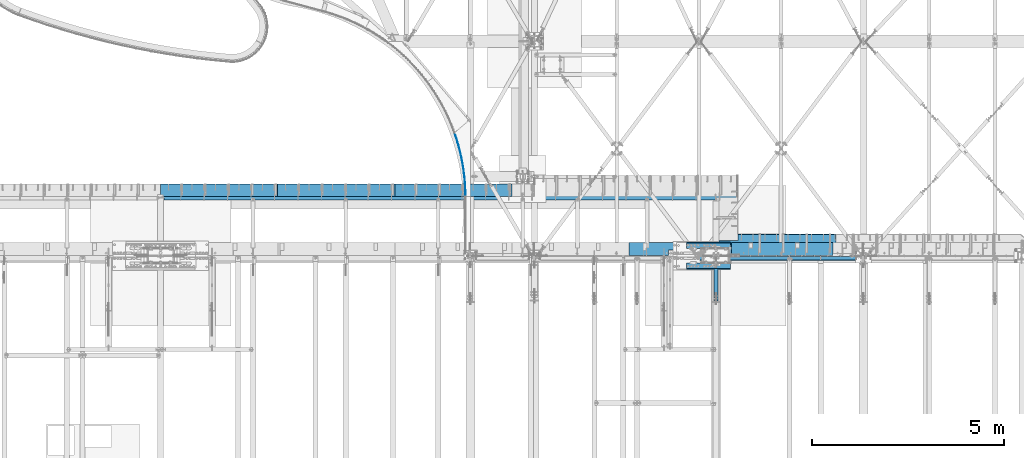
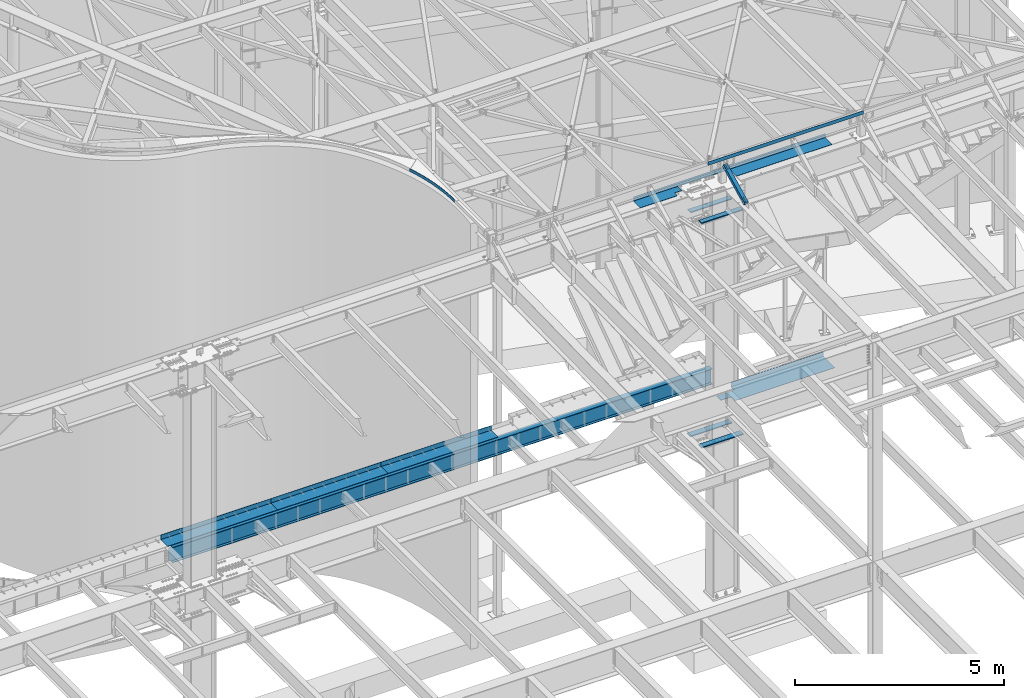
# One storey, part 1146 of 1763: 13 beams, 1 member, 8 elements without a shape of their own.
"""IFC2X3 building model written with IfcOpenShell, lengths in millimetres."""

from ifc_helpers import new_model, si_unit, frame, origin_with_axes, place, context, subcontext, project, spatial, faceted_brep, material, type_object, element, aggregate, save


model = new_model("IFC2X3")

# Units and contexts
model_context = context("Model", 3, precision=1e-05, world=origin_with_axes())
body_context = subcontext(model_context, "Body", "Model", "MODEL_VIEW")
ifc_project = project(units=[si_unit("LENGTHUNIT", "METRE", prefix="MILLI"), si_unit("AREAUNIT", "SQUARE_METRE"), si_unit("VOLUMEUNIT", "CUBIC_METRE"), si_unit("MASSUNIT", "GRAM", prefix="KILO"), si_unit("TIMEUNIT", "SECOND"), si_unit("PLANEANGLEUNIT", "RADIAN"), si_unit("SOLIDANGLEUNIT", "STERADIAN"), si_unit("THERMODYNAMICTEMPERATUREUNIT", "DEGREE_CELSIUS"), si_unit("LUMINOUSINTENSITYUNIT", "LUMEN")], contexts=[model_context])

# Site, building, storey
site_placement = place(None, origin_with_axes())
site = spatial("IfcSite", under=ifc_project, at=site_placement, CompositionType="ELEMENT")
building_placement = place(site_placement, origin_with_axes())
building = spatial("IfcBuilding", under=site, at=building_placement, Name="Undefined", CompositionType="ELEMENT")
storey_placement = place(building_placement, origin_with_axes())
storey = spatial("IfcBuildingStorey", under=building, at=storey_placement, Name="Undefined", CompositionType="ELEMENT", Elevation=0.0)

# Assembly, beam
assembly_1_placement = place(storey_placement, origin_with_axes())
assembly_1 = element("IfcElementAssembly", 1, at=assembly_1_placement, inside=storey, Name="BEAM", AssemblyPlace="NOTDEFINED", PredefinedType="RIGID_FRAME")
ifc_material_1 = material(Name="STEEL/A36")
beam_type_1 = type_object("IfcBeamType", Name="L4X4X1/4", PredefinedType="NOTDEFINED")
beam_1_placement = place(assembly_1_placement, frame((-35405.0896174446, 52050.9499997281, 12496.8), z_axis=(0.0, 1.0, 0.0), x_axis=(1.0, 0.0, 0.0)))
beam_1 = element("IfcBeam", 2, at=beam_1_placement, type_object=beam_type_1, material=ifc_material_1, Name="V. BRACE", ObjectType="L4X4X1/4", context=body_context, shape_type="Brep", body=[
    faceted_brep([(-3.63797880709171e-11, 50.8000000000011, -50.8000000000538), (-1.96450855582952e-10, 50.8000000000393, 50.7999999999374), (4292.59999999623, 50.7999999999993, 50.8000000000029), (4292.59999999623, 50.7999999999993, -50.8000000000029), (-1.81898940354586e-10, 44.4500000000371, 50.7999999999374), (4292.59999999623, 44.4500000000007, 50.8000000000029), (-2.18278728425503e-11, 44.4500000000007, -44.450000000048), (4292.59999999623, 44.4500000000007, -44.4499999999971), (1.96450855582952e-10, -50.8000000000338, -44.4499999999534), (4292.59999999623, -50.7999999999993, -44.4499999999971), (2.11002770811319e-10, -50.8000000000357, -50.799999999952), (4292.59999999623, -50.7999999999993, -50.8000000000029)], [[[0, 1, 2, 3]], [[1, 4, 5, 2]], [[4, 6, 7, 5]], [[6, 8, 9, 7]], [[8, 10, 11, 9]], [[10, 0, 3, 11]], [[5, 7, 9, 11, 3, 2]], [[10, 8, 6, 4, 1, 0]]]),
])
aggregate(assembly_1, [beam_1])

assembly_2_placement = place(storey_placement, origin_with_axes())
assembly_2 = element("IfcElementAssembly", 3, at=assembly_2_placement, inside=storey, Name="BEAM", AssemblyPlace="NOTDEFINED", PredefinedType="RIGID_FRAME")
beam_type_2 = type_object("IfcBeamType", PredefinedType="NOTDEFINED")
beam_2_placement = place(assembly_2_placement, frame((-41466.5130414055, 53658.2333127018, 12526.764063), z_axis=(0.0, 0.0, 1.0), x_axis=(-0.169409504044444, 0.985545747258551, 0.0)))
beam_2 = element("IfcBeam", 4, at=beam_2_placement, type_object=beam_type_2, material=ifc_material_1, Name="PLATE", context=body_context, shape_type="Brep", body=[
    faceted_brep([(0.536603266024031, 3.12932611513679, -44.4500000000007), (0.536603266024031, 3.12932611513679, 44.4500000000007), (84.1425468328453, -10.4773142307095, 44.4500000000007), (84.1425468328453, -10.4773142307095, -44.4500000000007), (-0.536603266009479, -3.12932611514043, 44.4500000000007), (-0.536603266009479, -3.12932611514043, -44.4500000000007), (83.1757768934986, -16.7532887275083, -44.4500000000007), (83.1757768934986, -16.7532887275083, 44.4500000000007), (167.967496958365, -22.6622310401872, 44.4500000000007), (167.967496958365, -22.6622310401872, -44.4500000000007), (167.107442423381, -28.9537178435494, -44.4500000000007), (167.107442423381, -28.9537178435494, 44.4500000000007), (251.987278942353, -33.4219102436691, 44.4500000000007), (251.987278942353, -33.4219102436691, -44.4500000000007), (251.2341878472, -39.7270949199738, -44.4500000000007), (251.2341878472, -39.7270949199738, 44.4500000000007), (336.177661896058, -42.7532488029829, 44.4500000000007), (336.177661896058, -42.7532488029829, -44.4500000000007), (335.531751428469, -49.0703129682297, -44.4500000000007), (335.531751428469, -49.0703129682297, 44.4500000000007), (420.514365730225, -50.6535556063463, 44.4500000000007), (420.514365730225, -50.6535556063463, -44.4500000000007), (419.97582216758, -56.9806774505196, -44.4500000000007), (419.97582216758, -56.9806774505196, 44.4500000000007), (504.973068157407, -57.1205522443997, 44.4500000000007), (504.973068157407, -57.1205522443997, -44.4500000000007), (504.542046812989, -63.4559070569303, -44.4500000000007), (504.542046812989, -63.4559070569303, 44.4500000000007), (589.529411706339, -62.1523736673771, 44.4500000000007), (589.529411706339, -62.1523736673771, -44.4500000000007), (589.2060368846, -68.4941343633218, -44.4500000000007), (589.2060368846, -68.4941343633218, 44.4500000000007), (674.159010746589, -65.7475687229162, 44.4500000000007), (674.159010746589, -65.7475687229162, -44.4500000000007), (673.943375707197, -72.0939063699225, -44.4500000000007), (673.943375707197, -72.0939063699225, 44.4500000000007), (758.837458521135, -67.9051005745787, 44.4500000000007), (758.837458521135, -67.9051005745787, -44.4500000000007), (758.729625452179, -74.254184920308, -44.4500000000007), (758.729625452179, -74.254184920308, 44.4500000000007), (843.540334185302, -68.6243470008631, 44.4500000000007), (843.540334185302, -68.6243470008631, -44.4500000000007), (843.540334185287, -74.9743470008652, -44.4500000000007), (843.540334185287, -74.9743470008652, 44.4500000000007), (928.243209849454, -67.9051005746769, 44.4500000000007), (928.243209849454, -67.9051005746769, -44.4500000000007), (928.351042918403, -74.2541849204135, -44.4500000000007), (928.351042918403, -74.2541849204135, 44.4500000000007), (1012.92165762401, -65.7475687231126, 44.4500000000007), (1012.92165762401, -65.7475687231126, -44.4500000000007), (1013.13729266339, -72.0939063701189, -44.4500000000007), (1013.13729266339, -72.0939063701189, 44.4500000000007), (1097.55125666426, -62.1523736676681, 44.4500000000007), (1097.55125666426, -62.1523736676681, -44.4500000000007), (1097.874631486, -68.4941343636165, -44.4500000000007), (1097.874631486, -68.4941343636165, 44.4500000000007), (1182.1076002132, -57.1205522447817, 44.4500000000007), (1182.1076002132, -57.1205522447817, -44.4500000000007), (1182.5386215576, -63.4559070573159, -44.4500000000007), (1182.5386215576, -63.4559070573159, 44.4500000000007), (1266.56630264039, -50.6535556068193, 44.4500000000007), (1266.56630264039, -50.6535556068193, -44.4500000000007), (1267.10484620303, -56.9806774509998, -44.4500000000007), (1267.10484620303, -56.9806774509998, 44.4500000000007), (1350.90300647457, -42.7532488035649, 44.4500000000007), (1350.90300647457, -42.7532488035649, -44.4500000000007), (1351.54891694215, -49.0703129688118, -44.4500000000007), (1351.54891694215, -49.0703129688118, 44.4500000000007), (1435.09338942828, -33.4219102443385, 44.4500000000007), (1435.09338942828, -33.4219102443385, -44.4500000000007), (1435.84648052343, -39.7270949206577, -44.4500000000007), (1435.84648052343, -39.7270949206577, 44.4500000000007), (1519.11317141227, -22.6622310409621, 44.4500000000007), (1519.11317141227, -22.6622310409621, -44.4500000000007), (1519.97322594725, -28.9537178443206, -44.4500000000007), (1519.97322594725, -28.9537178443206, 44.4500000000007), (1602.93812153781, -10.4773142315826, 44.4500000000007), (1602.93812153781, -10.4773142315826, -44.4500000000007), (1603.90489147715, -16.7532887283705, -44.4500000000007), (1603.90489147715, -16.7532887283705, 44.4500000000007), (1686.54406510465, 3.12932611417273, 44.4500000000007), (1686.54406510465, 3.12932611417273, -44.4500000000007), (1687.61727163669, -3.12932611610813, 44.4500000000007), (1687.61727163669, -3.12932611610813, -44.4500000000007)], [[[0, 1, 2, 3]], [[4, 5, 6, 7]], [[5, 4, 1, 0]], [[3, 2, 8, 9]], [[7, 6, 10, 11]], [[9, 8, 12, 13]], [[11, 10, 14, 15]], [[13, 12, 16, 17]], [[15, 14, 18, 19]], [[17, 16, 20, 21]], [[19, 18, 22, 23]], [[21, 20, 24, 25]], [[23, 22, 26, 27]], [[25, 24, 28, 29]], [[27, 26, 30, 31]], [[29, 28, 32, 33]], [[31, 30, 34, 35]], [[33, 32, 36, 37]], [[35, 34, 38, 39]], [[37, 36, 40, 41]], [[39, 38, 42, 43]], [[41, 40, 44, 45]], [[43, 42, 46, 47]], [[45, 44, 48, 49]], [[47, 46, 50, 51]], [[49, 48, 52, 53]], [[51, 50, 54, 55]], [[53, 52, 56, 57]], [[55, 54, 58, 59]], [[57, 56, 60, 61]], [[59, 58, 62, 63]], [[61, 60, 64, 65]], [[63, 62, 66, 67]], [[65, 64, 68, 69]], [[67, 66, 70, 71]], [[69, 68, 72, 73]], [[71, 70, 74, 75]], [[73, 72, 76, 77]], [[75, 74, 78, 79]], [[77, 76, 80, 81]], [[76, 72, 68, 64, 60, 56, 52, 48, 44, 40, 36, 32, 28, 24, 20, 16, 12, 8, 2, 1, 4, 7, 11, 15, 19, 23, 27, 31, 35, 39, 43, 47, 51, 55, 59, 63, 67, 71, 75, 79, 82, 80]], [[79, 78, 83, 82]], [[78, 74, 70, 66, 62, 58, 54, 50, 46, 42, 38, 34, 30, 26, 22, 18, 14, 10, 6, 5, 0, 3, 9, 13, 17, 21, 25, 29, 33, 37, 41, 45, 49, 53, 57, 61, 65, 69, 73, 77, 81, 83]], [[82, 83, 81, 80]]]),
])
aggregate(assembly_2, [beam_2])

# Assembly, beams
assembly_3_placement = place(storey_placement, origin_with_axes())
assembly_3 = element("IfcElementAssembly", 5, at=assembly_3_placement, inside=storey, Name="COLUMN", AssemblyPlace="NOTDEFINED", PredefinedType="RIGID_FRAME")
ifc_material_2 = material(Name="STEEL/A572-50")
beam_type_3 = type_object("IfcBeamType", PredefinedType="NOTDEFINED")
beam_3_placement = place(assembly_3_placement, frame((-34567.2497736984, 52384.3250002128, 10983.9124917654), z_axis=(0.0, -1.0, 0.0), x_axis=(-1.0, 0.0, 0.0)))
beam_3 = element("IfcBeam", 6, at=beam_3_placement, type_object=beam_type_3, material=ifc_material_2, Name="PLATE", context=body_context, shape_type="Brep", body=[
    faceted_brep([(0.0, 14.2875000000004, -69.8499999999985), (0.0, 14.2875000000004, 69.8499999999985), (1143.0, 14.2875000000004, 69.8499999999985), (1143.0, 14.2875000000004, -69.8499999999985), (0.0, -14.2875000000004, 69.8499999999985), (1143.0, -14.2875000000004, 69.8499999999985), (0.0, -14.2875000000004, -69.8499999999985), (1143.0, -14.2875000000004, -69.8499999999985)], [[[0, 1, 2, 3]], [[1, 4, 5, 2]], [[4, 6, 7, 5]], [[6, 0, 3, 7]], [[5, 7, 3, 2]], [[6, 4, 1, 0]]]),
])
beam_4_placement = place(assembly_3_placement, frame((-34567.2497736984, 51857.2750002128, 10983.9124917654), z_axis=(0.0, -1.0, 0.0), x_axis=(-1.0, 0.0, 0.0)))
beam_4 = element("IfcBeam", 7, at=beam_4_placement, type_object=beam_type_3, material=ifc_material_2, Name="PLATE", context=body_context, shape_type="Brep", body=[
    faceted_brep([(0.0, 14.2875000000004, -69.8499999999985), (0.0, 14.2875000000004, 69.8499999999985), (1143.0, 14.2875000000004, 69.8499999999985), (1143.0, 14.2875000000004, -69.8499999999985), (0.0, -14.2875000000004, 69.8499999999985), (1143.0, -14.2875000000004, 69.8499999999985), (0.0, -14.2875000000004, -69.8499999999985), (1143.0, -14.2875000000004, -69.8499999999985)], [[[0, 1, 2, 3]], [[1, 4, 5, 2]], [[4, 6, 7, 5]], [[6, 0, 3, 7]], [[5, 7, 3, 2]], [[6, 4, 1, 0]]]),
])
beam_type_4 = type_object("IfcBeamType", PredefinedType="NOTDEFINED")
beam_5_placement = place(assembly_3_placement, frame((-34567.2497736984, 52393.85, 4433.8875), z_axis=(0.0, -1.0, 0.0), x_axis=(-1.0, 0.0, 0.0)))
beam_5 = element("IfcBeam", 8, at=beam_5_placement, type_object=beam_type_4, material=ifc_material_2, Name="PLATE", context=body_context, shape_type="Brep", body=[
    faceted_brep([(0.0, 14.2875000000004, -79.375), (0.0, 14.2875000000004, 79.375), (1152.52499999999, 14.2875000000004, 79.375), (1152.52499999999, 14.2875000000004, -79.375), (0.0, -14.2875000000004, 79.375), (1152.52499999999, -14.2875000000004, 79.375), (0.0, -14.2875000000004, -79.375), (1152.52499999999, -14.2875000000004, -79.375)], [[[0, 1, 2, 3]], [[1, 4, 5, 2]], [[4, 6, 7, 5]], [[6, 0, 3, 7]], [[5, 7, 3, 2]], [[6, 4, 1, 0]]]),
])
beam_6_placement = place(assembly_3_placement, frame((-34567.2497736984, 51847.75, 4433.8875), z_axis=(0.0, -1.0, 0.0), x_axis=(-1.0, 0.0, 0.0)))
beam_6 = element("IfcBeam", 9, at=beam_6_placement, type_object=beam_type_4, material=ifc_material_2, Name="PLATE", context=body_context, shape_type="Brep", body=[
    faceted_brep([(0.0, 14.2875000000004, -79.375), (0.0, 14.2875000000004, 79.375), (1152.52499999999, 14.2875000000004, 79.375), (1152.52499999999, 14.2875000000004, -79.375), (0.0, -14.2875000000004, 79.375), (1152.52499999999, -14.2875000000004, 79.375), (0.0, -14.2875000000004, -79.375), (1152.52499999999, -14.2875000000004, -79.375)], [[[0, 1, 2, 3]], [[1, 4, 5, 2]], [[4, 6, 7, 5]], [[6, 0, 3, 7]], [[5, 7, 3, 2]], [[6, 4, 1, 0]]]),
])
aggregate(assembly_3, [beam_3, beam_4, beam_5, beam_6])

# Assembly, member
assembly_4_placement = place(storey_placement, origin_with_axes())
assembly_4 = element("IfcElementAssembly", 10, at=assembly_4_placement, inside=storey, Name="BEAM", AssemblyPlace="NOTDEFINED", PredefinedType="RIGID_FRAME")
ifc_material_3 = material()
member_type = type_object("IfcMemberType", Name="HSS4X4X1/2", PredefinedType="NOTDEFINED")
member_placement = place(assembly_4_placement, frame((-34949.8372736984, 50822.4448748991, 11720.6374724137), z_axis=(-1.0, 0.0, 0.0), x_axis=(0.0, 0.894427191199916, 0.447213595099959)))
member = element("IfcMember", 11, at=member_placement, type_object=member_type, material=ifc_material_3, Name="BEAM", ObjectType="HSS4X4X1/2", context=body_context, shape_type="Brep", body=[
    faceted_brep([(1312.61289971653, -50.8000000018983, -7.9375), (1312.61289971651, -38.1000000018903, -7.9375), (1161.80039971038, -38.1000000016793, -7.9375), (1161.8003997104, -50.8000000016891, -7.9375), (1158.762849966, -38.1000000016738, -7.33329378931012), (1158.76284996603, -50.8000000016782, -7.33329378931012), (1156.18773963476, -38.1000000016684, -5.61266007566883), (1156.18773963477, -50.8000000016764, -5.61266007566883), (1154.46710592113, -38.1000000016629, -3.03754974439653), (1154.46710592115, -50.8000000016727, -3.03754974439653), (1153.86289971044, -38.1000000016684, 0.0), (1153.86289971046, -50.8000000016746, 0.0), (1154.46710592113, -38.1000000016629, 3.03754974439653), (1154.46710592115, -50.8000000016727, 3.03754974439653), (1156.18773963476, -38.1000000016684, 5.61266007566883), (1156.18773963477, -50.8000000016764, 5.61266007566883), (1158.762849966, -38.1000000016738, 7.33329378931012), (1158.76284996603, -50.8000000016782, 7.33329378931012), (1161.80039971038, -38.1000000016793, 7.9375), (1161.8003997104, -50.8000000016891, 7.9375), (1312.61289971653, -50.8000000018983, 7.9375), (1312.61289971651, -38.1000000018903, 7.9375), (1312.61289971639, 38.0999999981505, -7.9375), (1312.61289971636, 50.7999999981585, -7.9375), (1161.80039971021, 50.7999999983731, -7.9375), (1161.80039971024, 38.0999999983687, -7.9375), (1158.76284996585, 50.7999999983786, -7.33329378931012), (1158.76284996586, 38.0999999983705, -7.33329378931012), (1156.18773963459, 50.7999999983804, -5.61266007566883), (1156.18773963462, 38.099999998376, -5.61266007566883), (1154.46710592096, 50.7999999983858, -3.03754974439653), (1154.46710592099, 38.0999999983778, -3.03754974439653), (1153.86289971027, 50.7999999983858, 0.0), (1153.86289971031, 38.0999999983796, 0.0), (1154.46710592096, 50.7999999983858, 3.03754974439653), (1154.46710592099, 38.0999999983778, 3.03754974439653), (1156.18773963459, 50.7999999983804, 5.61266007566883), (1156.18773963462, 38.099999998376, 5.61266007566883), (1158.76284996585, 50.7999999983786, 7.33329378931012), (1158.76284996586, 38.0999999983705, 7.33329378931012), (1161.80039971021, 50.7999999983731, 7.9375), (1161.80039971024, 38.0999999983687, 7.9375), (1312.61289971639, 38.0999999981505, 7.9375), (1312.61289971636, 50.7999999981585, 7.9375), (166.342448712407, -38.100000000255, 38.0999999999985), (166.342448712276, 38.0999999997875, 38.0999999999985), (1312.61289971639, 38.0999999981505, 38.0999999999985), (1312.61289971651, -38.1000000018903, 38.0999999999985), (322.767606017376, -38.1000000004806, 5.61266007592349), (320.192495686126, -38.1000000004788, 7.33329378956478), (317.154945941751, -38.1000000004733, 7.93750000025466), (166.342448712407, -38.100000000255, 7.93750000025466), (1312.61289971651, -38.1000000018903, -38.0999999999985), (166.342448712407, -38.100000000255, -38.0999999999985), (166.342448712407, -38.100000000255, -7.93749999974898), (317.154945941751, -38.1000000004715, -7.93749999987267), (320.192495686126, -38.1000000004769, -7.33329378918279), (322.767606017376, -38.1000000004806, -5.61266007554514), (324.488239731007, -38.1000000004842, -3.03754974427284), (325.092445941693, -38.1000000004842, 2.5465851649642e-10), (324.488239731007, -38.1000000004842, 3.03754974465119), (166.342448712276, 38.0999999997875, -38.0999999999985), (1312.61289971639, 38.0999999981505, -38.0999999999985), (166.342448712276, 38.0999999997875, 7.93750000025466), (166.342448712254, 50.7999999997955, 7.93750000025466), (317.154945941591, 50.7999999995791, 7.93750000025466), (317.15494594162, 38.0999999995711, 7.93750000025466), (320.192495685966, 50.7999999995736, 7.33329378956478), (320.192495685995, 38.0999999995693, 7.33329378956478), (322.767606017216, 50.7999999995718, 5.61266007592349), (322.767606017245, 38.0999999995638, 5.61266007592349), (324.488239730847, 50.7999999995682, 3.03754974465119), (324.488239730868, 38.0999999995638, 3.03754974465119), (325.092445941533, 50.7999999995682, 2.5465851649642e-10), (325.092445941555, 38.0999999995583, 2.5465851649642e-10), (324.488239730847, 50.7999999995682, -3.03754974427284), (324.488239730861, 38.0999999995602, -3.03754974427284), (322.767606017209, 50.79999999957, -5.61266007554514), (322.767606017245, 38.0999999995638, -5.61266007554514), (320.192495685966, 50.7999999995754, -7.33329378918279), (320.19249568598, 38.0999999995674, -7.33329378918279), (317.154945941591, 50.7999999995791, -7.93749999987267), (317.154945941606, 38.0999999995693, -7.93749999987267), (166.342448712254, 50.7999999997955, -7.93749999974898), (166.342448712276, 38.0999999997875, -7.93749999974898), (166.342448712254, 50.7999999997955, -50.7999999999993), (166.342448712421, -50.8000000002612, -50.7999999999993), (166.342448712421, -50.8000000002612, -7.93749999974898), (317.154945941773, -50.8000000004795, -7.93749999987267), (320.192495686155, -50.8000000004831, -7.33329378918279), (322.767606017391, -50.8000000004868, -5.61266007554514), (324.488239731028, -50.800000000494, -3.03754974427284), (325.092445941715, -50.8000000004904, 2.5465851649642e-10), (324.488239731028, -50.800000000494, 3.03754974465119), (322.767606017405, -50.8000000004849, 5.61266007592349), (320.192495686155, -50.8000000004849, 7.33329378956478), (317.154945941787, -50.8000000004795, 7.93750000025466), (166.342448712421, -50.8000000002612, 7.93750000025466), (166.342448712421, -50.8000000002612, 50.7999999999993), (166.342448712254, 50.7999999997955, 50.7999999999993), (1312.61289971653, -50.8000000018983, 50.7999999999993), (1312.61289971636, 50.7999999981585, 50.7999999999993), (1312.61289971636, 50.7999999981585, -50.7999999999993), (1312.61289971653, -50.8000000018983, -50.7999999999993)], [[[0, 1, 2, 3]], [[3, 2, 4, 5]], [[5, 4, 6, 7]], [[7, 6, 8, 9]], [[9, 8, 10, 11]], [[11, 10, 12, 13]], [[13, 12, 14, 15]], [[15, 14, 16, 17]], [[17, 16, 18, 19]], [[20, 19, 18, 21]], [[22, 23, 24, 25]], [[25, 24, 26, 27]], [[27, 26, 28, 29]], [[29, 28, 30, 31]], [[31, 30, 32, 33]], [[33, 32, 34, 35]], [[35, 34, 36, 37]], [[37, 36, 38, 39]], [[39, 38, 40, 41]], [[42, 41, 40, 43]], [[44, 45, 46, 47]], [[48, 49, 50, 51, 44, 47, 21, 18, 16, 14, 12, 10, 8, 6, 4, 2, 1, 52, 53, 54, 55, 56, 57, 58, 59, 60]], [[61, 53, 52, 62]], [[63, 64, 65, 66]], [[66, 65, 67, 68]], [[68, 67, 69, 70]], [[70, 69, 71, 72]], [[72, 71, 73, 74]], [[74, 73, 75, 76]], [[76, 75, 77, 78]], [[78, 77, 79, 80]], [[80, 79, 81, 82]], [[82, 81, 83, 84]], [[53, 61, 84, 83, 85, 86, 87, 54]], [[88, 55, 54, 87]], [[89, 56, 55, 88]], [[90, 57, 56, 89]], [[91, 58, 57, 90]], [[92, 59, 58, 91]], [[93, 60, 59, 92]], [[94, 48, 60, 93]], [[95, 49, 48, 94]], [[96, 50, 49, 95]], [[97, 51, 50, 96]], [[98, 99, 64, 63, 45, 44, 51, 97]], [[99, 98, 100, 101]], [[47, 46, 42, 43, 101, 100, 20, 21]], [[69, 67, 65, 64, 99, 101, 43, 40, 38, 36, 34, 32, 30, 28, 26, 24, 23, 102, 85, 83, 81, 79, 77, 75, 73, 71]], [[86, 85, 102, 103]], [[90, 89, 88, 87, 86, 103, 0, 3, 5, 7, 9, 11, 13, 15, 17, 19, 20, 100, 98, 97, 96, 95, 94, 93, 92, 91]], [[103, 102, 23, 22, 62, 52, 1, 0]], [[78, 80, 82, 84, 61, 62, 22, 25, 27, 29, 31, 33, 35, 37, 39, 41, 42, 46, 45, 63, 66, 68, 70, 72, 74, 76]]]),
])
aggregate(assembly_4, [member])

# Assembly, beam
assembly_5_placement = place(storey_placement, origin_with_axes())
assembly_5 = element("IfcElementAssembly", 12, at=assembly_5_placement, inside=storey, Name="BEAM", AssemblyPlace="NOTDEFINED", PredefinedType="RIGID_FRAME")
beam_type_5 = type_object("IfcBeamType", PredefinedType="NOTDEFINED")
beam_7_placement = place(assembly_5_placement, frame((-36080.1372736983, 52133.5000002128, 11752.2624917654), z_axis=(-1.0, 0.0, 0.0), x_axis=(0.0, 1.0, 0.0)))
beam_7 = element("IfcBeam", 13, at=beam_7_placement, type_object=beam_type_5, material=ifc_material_1, Name="BENT_PLATE", context=body_context, shape_type="Brep", body=[
    faceted_brep([(0.0, -4.76250000000073, 106.362415039068), (0.0, 4.76250000000073, 106.362415039068), (133.349999999999, 4.76250000000073, 106.362415039068), (133.349999999999, -4.76250000000073, 106.362415039068), (133.349999999999, 4.76250000000073, -96.8375361328071), (133.349999999999, -4.76250000000073, -96.8375361328071), (327.02498779296, -4.76250000000073, -96.8385126953071), (327.02498779296, 4.76250000000073, -96.8385126953071), (327.024987792967, 4.76250000000073, -1127.1245), (327.024987792975, -4.76250000000073, -1127.1245), (336.549987792969, 4.76250000000073, 1127.1245), (0.0, 4.76250000000073, 1127.1245), (0.0, -4.76250000000073, 1127.1245), (327.024987792975, -4.76250000000073, 1127.1245), (327.024987792975, -122.237499999999, 1127.1245), (336.549987792969, -122.237499999999, 1127.1245), (336.549987792969, 4.76250000000073, -1127.1245), (336.549987792969, -122.237499999999, -1127.1245), (327.024987792975, -122.237499999999, -1127.1245), (327.024987792975, -99.5375007629391, -1127.1245)], [[[0, 1, 2, 3]], [[3, 2, 4, 5]], [[6, 7, 8, 9]], [[5, 4, 7, 6]], [[10, 11, 12, 13, 14, 15]], [[16, 10, 15, 17]], [[14, 18, 17, 15]], [[13, 6, 9, 19, 18, 14]], [[16, 17, 18, 19, 9, 8]], [[2, 1, 11, 10, 16, 8, 7, 4]], [[12, 11, 1, 0]], [[13, 12, 0, 3, 5, 6]]]),
])
aggregate(assembly_5, [beam_7])

assembly_6_placement = place(storey_placement, origin_with_axes())
assembly_6 = element("IfcElementAssembly", 14, at=assembly_6_placement, inside=storey, Name="BEAM", AssemblyPlace="NOTDEFINED", PredefinedType="RIGID_FRAME")
beam_8_placement = place(assembly_6_placement, frame((-33422.6617736984, 52133.5000002128, 11752.2624917654), z_axis=(-1.0, 0.0, 0.0), x_axis=(0.0, 1.0, 0.0)))
beam_8 = element("IfcBeam", 15, at=beam_8_placement, type_object=beam_type_5, material=ifc_material_1, Name="BENT_PLATE", context=body_context, shape_type="Brep", body=[
    faceted_brep([(327.024987792975, -4.76250000000073, 1125.53799438482), (327.024993896863, 4.76250000000073, 1125.53799438482), (0.0, 4.76250000000073, 1125.53799438482), (0.0, -4.76250000000073, 1125.53799438482), (327.024987792967, -4.76250000000073, 1524.00000000001), (327.024987792967, 4.76250000000073, 1524.0), (327.024987792975, -4.76250000000073, -1524.0), (0.0, -4.76249999999982, -1524.0), (0.0, 4.76249999999982, -1524.0), (336.549987792969, 4.76250000000073, -1524.0), (336.549987792969, -122.237499999999, -1524.0), (327.024987792975, -122.237499999999, -1524.0), (336.549987792969, 4.76250000000073, 1524.0), (336.549987792969, -122.237499999999, 1524.0), (327.024987792975, -122.237499999999, 1524.0), (327.024987792975, -99.5365104778575, 1524.0)], [[[0, 1, 2, 3]], [[4, 5, 1, 0]], [[6, 7, 8, 9, 10, 11]], [[9, 12, 13, 10]], [[14, 11, 10, 13]], [[15, 4, 0, 6, 11, 14]], [[7, 6, 0, 3]], [[8, 7, 3, 2]], [[12, 9, 8, 2, 1, 5]], [[15, 14, 13, 12, 5, 4]]]),
])
aggregate(assembly_6, [beam_8])

assembly_7_placement = place(storey_placement, origin_with_axes())
assembly_7 = element("IfcElementAssembly", 16, at=assembly_7_placement, inside=storey, Name="BEAM", AssemblyPlace="NOTDEFINED", PredefinedType="RIGID_FRAME")
beam_type_6 = type_object("IfcBeamType", PredefinedType="NOTDEFINED")
beam_9_placement = place(assembly_7_placement, frame((-33349.6372736984, 52131.1187449422, 5199.0625), z_axis=(1.0, 0.0, 0.0), x_axis=(0.0, 1.0, 0.0)))
beam_9 = element("IfcBeam", 17, at=beam_9_placement, type_object=beam_type_6, material=ifc_material_1, Name="BENT PLATE", context=body_context, shape_type="Brep", body=[
    faceted_brep([(180.374352277817, -4.76249999999982, -1230.31250244449), (180.374352277817, 4.76249999999982, -1230.31250244449), (180.181255057774, 4.76249999999982, -1524.0), (180.181255057774, -4.76249999999982, -1524.0), (0.0, -4.76249999999982, -1230.31250396137), (0.0, 4.76249999999982, -1230.31250396137), (548.4812866211, 4.76249999999982, 1524.0), (548.4812866211, 134.937496948242, 1524.0), (548.4812866211, 134.937496948242, -1031.875), (548.4812866211, 4.76249999999982, -1031.875), (0.0, 4.76249999999982, 1524.0), (0.0, -4.76249999999982, 1524.0), (558.006286621094, -4.76249999999982, 1524.0), (558.006286621094, 134.937496948242, 1524.0), (558.006264213014, -4.76249999999982, -1031.875), (558.006286621094, 134.937496948242, -1031.875), (389.736259940553, -4.76249999999982, -1031.875), (389.736259940553, 4.76249999999982, -1031.875), (389.736259940553, -4.76249999999982, -1524.0), (389.736259940553, 4.76249999999982, -1524.0)], [[[0, 1, 2, 3]], [[4, 5, 1, 0]], [[6, 7, 8, 9]], [[6, 10, 11, 12, 13, 7]], [[13, 12, 14, 15]], [[7, 13, 15, 8]], [[14, 16, 17, 9, 8, 15]], [[18, 19, 17, 16]], [[19, 18, 3, 2]], [[10, 6, 9, 17, 19, 2, 1, 5]], [[11, 10, 5, 4]], [[18, 16, 14, 12, 11, 4, 0, 3]]]),
])
aggregate(assembly_7, [beam_9])

# Assembly, beams
assembly_8_placement = place(storey_placement, origin_with_axes())
assembly_8 = element("IfcElementAssembly", 18, at=assembly_8_placement, inside=storey, Name="BEAM", AssemblyPlace="NOTDEFINED", PredefinedType="RIGID_FRAME")
beam_type_7 = type_object("IfcBeamType", PredefinedType="NOTDEFINED")
beam_10_placement = place(assembly_8_placement, frame((-41782.4372736983, 53657.5, 5199.0625), z_axis=(1.0, 0.0, 0.0), x_axis=(0.0, 1.0, 0.0)))
beam_10 = element("IfcBeam", 19, at=beam_10_placement, type_object=beam_type_7, material=ifc_material_1, Name="BENT PLATE", context=body_context, shape_type="Brep", body=[
    faceted_brep([(0.0, -4.76249999999982, -1524.0), (0.0, -4.76249999999982, 1524.0), (0.0, 4.76249999999982, 1524.0), (0.0, 4.76249999999982, -1524.0), (327.024987792967, 4.76250000000073, 1524.0), (327.025018310553, 4.76249999999982, -1524.0), (336.550018310547, -4.76249999999982, -1524.0), (336.550018310547, -4.76249999999982, 1524.0), (327.025018310553, 134.937496948242, 1524.0), (327.025018310553, 134.937496948242, -1524.0), (336.550018310547, 134.937496948242, 1524.0), (336.550018310547, 134.937496948242, -1524.0)], [[[0, 1, 2, 3]], [[3, 2, 4, 5]], [[1, 0, 6, 7]], [[5, 4, 8, 9]], [[4, 2, 1, 7, 10, 8]], [[7, 6, 11, 10]], [[6, 0, 3, 5, 9, 11]], [[10, 11, 9, 8]]]),
])
beam_11_placement = place(assembly_8_placement, frame((-44830.4372736983, 53657.5, 5199.0625), z_axis=(1.0, 0.0, 0.0), x_axis=(0.0, 1.0, 0.0)))
beam_11 = element("IfcBeam", 20, at=beam_11_placement, type_object=beam_type_7, material=ifc_material_1, Name="BENT PLATE", context=body_context, shape_type="Brep", body=[
    faceted_brep([(0.0, -4.76249999999982, -1524.0), (0.0, -4.76249999999982, 1524.0), (0.0, 4.76249999999982, 1524.0), (0.0, 4.76249999999982, -1524.0), (327.024987792967, 4.76250000000073, 1524.0), (327.025018310553, 4.76249999999982, -1524.0), (336.550018310547, -4.76249999999982, -1524.0), (336.550018310547, -4.76249999999982, 1524.0), (327.025018310553, 134.937496948242, 1524.0), (327.025018310553, 134.937496948242, -1524.0), (336.550018310547, 134.937496948242, 1524.0), (336.550018310547, 134.937496948242, -1524.0)], [[[0, 1, 2, 3]], [[3, 2, 4, 5]], [[1, 0, 6, 7]], [[5, 4, 8, 9]], [[4, 2, 1, 7, 10, 8]], [[7, 6, 11, 10]], [[6, 0, 3, 5, 9, 11]], [[10, 11, 9, 8]]]),
])
beam_12_placement = place(assembly_8_placement, frame((-47878.4372736983, 53657.5, 5199.0625), z_axis=(1.0, 0.0, 0.0), x_axis=(0.0, 1.0, 0.0)))
beam_12 = element("IfcBeam", 21, at=beam_12_placement, type_object=beam_type_7, material=ifc_material_1, Name="BENT PLATE", context=body_context, shape_type="Brep", body=[
    faceted_brep([(0.0, -4.76249999999982, -1524.0), (0.0, -4.76249999999982, 1524.0), (0.0, 4.76249999999982, 1524.0), (0.0, 4.76249999999982, -1524.0), (327.024987792967, 4.76250000000073, 1524.0), (327.025018310553, 4.76249999999982, -1524.0), (336.550018310547, -4.76249999999982, -1524.0), (336.550018310547, -4.76249999999982, 1524.0), (327.025018310553, 134.937496948242, 1524.0), (327.025018310553, 134.937496948242, -1524.0), (336.550018310547, 134.937496948242, 1524.0), (336.550018310547, 134.937496948242, -1524.0)], [[[0, 1, 2, 3]], [[3, 2, 4, 5]], [[1, 0, 6, 7]], [[5, 4, 8, 9]], [[4, 2, 1, 7, 10, 8]], [[7, 6, 11, 10]], [[6, 0, 3, 5, 9, 11]], [[10, 11, 9, 8]]]),
])
ifc_material_4 = material(Name="STEEL/A992")
beam_type_8 = type_object("IfcBeamType", Name="W18X40", PredefinedType="NOTDEFINED")
beam_13_placement = place(assembly_8_placement, frame((-49402.4372736983, 53644.8, 4967.2875), z_axis=(0.0, 0.0, 1.0), x_axis=(1.0, 0.0, 0.0)))
beam_13 = element("IfcBeam", 22, at=beam_13_placement, type_object=beam_type_8, material=ifc_material_4, Name="BEAM", ObjectType="W18X40", context=body_context, shape_type="Brep", body=[
    faceted_brep([(16.6687499999971, -3.96875, -195.5225), (16.6687499999971, 3.96875, -195.5225), (76.9937501907407, 3.96875, -195.5225), (76.9937501907407, -3.96875, -195.5225), (81.8538297087871, 3.96875, -196.489229922588), (81.8538297087871, -3.96875, -196.489229922588), (85.9740061769407, 3.96875, -199.242243823066), (85.9740061769407, -3.96875, -199.242243823066), (88.7270200774146, 3.96875, -203.36242029122), (88.7270200774146, -3.96875, -203.36242029122), (89.6937500000058, -3.96875, -208.222499809265), (89.6937500000058, 3.96875, -208.222499809265), (89.6937500000058, 3.96875, -214.3125), (89.6937500000058, 76.1999999999971, -214.3125), (89.6937500000058, 76.1999999999971, -227.0125), (89.6937500000058, -76.1999999999971, -227.0125), (89.6937500000058, -76.1999999999971, -214.3125), (89.6937500000058, -3.96875, -214.3125), (15020.925, -76.1999999999971, 214.3125), (15020.925, -76.1999999999971, 227.0125), (89.6937500000058, -76.1999999999971, 227.0125), (89.6937500000058, -76.1999999999971, 214.3125), (15020.925, 76.1999999999971, 227.0125), (89.6937500000058, 76.1999999999971, 227.0125), (15020.925, 76.1999999999971, 214.3125), (89.6937500000058, 76.1999999999971, 214.3125), (15020.925, 3.96875, 214.3125), (89.6937500000058, 3.96875, 214.3125), (76.9937501907407, -3.96875, 195.002501678467), (76.9937501907407, 3.96875, 195.002501678467), (16.6687499999971, 3.96875, 195.002501678467), (16.6687499999971, -3.96875, 195.002501678467), (81.8538297087871, -3.96875, 195.969231601054), (81.8538297087871, 3.96875, 195.969231601054), (85.9740061769407, -3.96875, 198.722245501533), (85.9740061769407, 3.96875, 198.722245501533), (88.7270200774146, -3.96875, 202.842421969686), (88.7270200774146, 3.96875, 202.842421969686), (89.6937500000058, -3.96875, 207.702501487732), (89.6937500000058, 3.96875, 207.702501487732), (89.6937500000058, -3.96875, 214.3125), (15020.925, -3.96875, 214.3125), (15020.925, 3.96875, -214.3125), (15020.925, -3.96875, -214.3125), (15020.925, -76.1999999999971, -214.3125), (15020.925, -76.1999999999971, -227.0125), (15020.925, 76.1999999999971, -227.0125), (15020.925, 76.1999999999971, -214.3125)], [[[0, 1, 2, 3]], [[3, 2, 4, 5]], [[5, 4, 6, 7]], [[7, 6, 8, 9]], [[10, 11, 12, 13, 14, 15, 16, 17]], [[9, 8, 11, 10]], [[18, 19, 20, 21]], [[19, 22, 23, 20]], [[22, 24, 25, 23]], [[24, 26, 27, 25]], [[28, 29, 30, 31]], [[32, 33, 29, 28]], [[34, 35, 33, 32]], [[36, 37, 35, 34]], [[38, 39, 37, 36]], [[20, 23, 25, 27, 39, 38, 40, 21]], [[41, 18, 21, 40]], [[42, 26, 24, 22, 19, 18, 41, 43, 44, 45, 46, 47]], [[44, 43, 17, 16]], [[45, 44, 16, 15]], [[46, 45, 15, 14]], [[47, 46, 14, 13]], [[42, 47, 13, 12]], [[6, 4, 2, 1, 30, 29, 33, 35, 37, 39, 27, 26, 42, 12, 11, 8]], [[31, 30, 1, 0]], [[43, 41, 40, 38, 36, 34, 32, 28, 31, 0, 3, 5, 7, 9, 10, 17]]]),
])
aggregate(assembly_8, [beam_10, beam_11, beam_12, beam_13])

save(model, "model.ifc")
